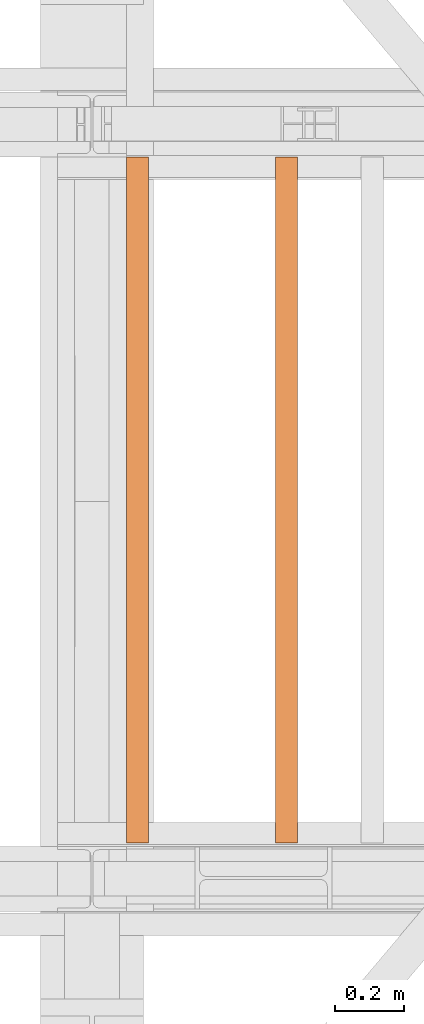
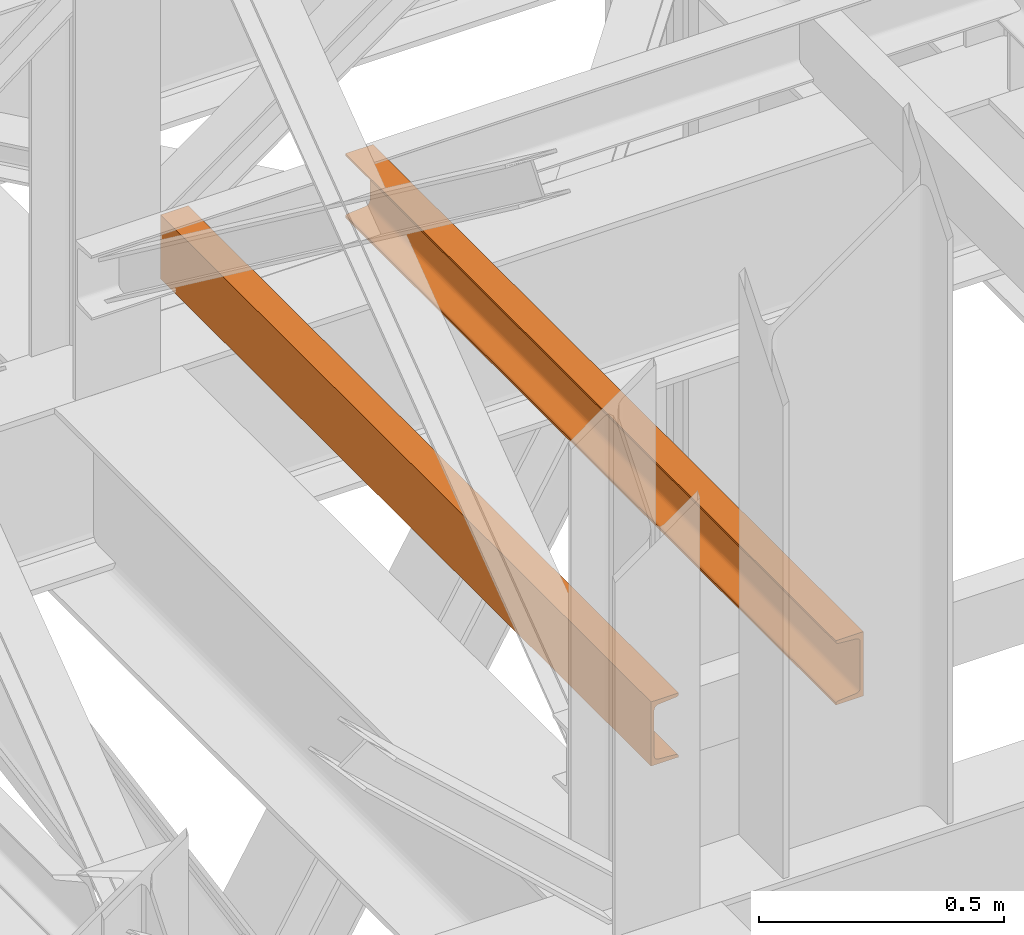
# One storey, part 170 of 208: 2 proxies.
"""IFC2X3 building model written with IfcOpenShell, lengths in millimetres."""

from ifc_helpers import new_model, entity, si_unit, converted_unit, frame, origin, origin_with_axes, place, context, subcontext, project, spatial, faceted_brep, element, save


model = new_model("IFC2X3")

# Units and contexts
model_context = context("Model", 3, precision=1e-05, world=origin())
plan_context = context("Plan", 3, precision=1e-05, world=origin())
body_context = subcontext(model_context, "Body", "Model", "MODEL_VIEW")
ifc_project = project(units=[si_unit("LENGTHUNIT", "METRE", prefix="MILLI"), converted_unit("PLANEANGLEUNIT", "DEGREE", entity("IfcPlaneAngleMeasure", 0.0174532925199433), si_unit("PLANEANGLEUNIT", "RADIAN"), dimensions=[0, 0, 0, 0, 0, 0, 0]), si_unit("AREAUNIT", "SQUARE_METRE"), si_unit("VOLUMEUNIT", "CUBIC_METRE")], contexts=[model_context, plan_context])

# Building, storey
building_placement = place(None, origin())
building = spatial("IfcBuilding", under=ifc_project, at=building_placement, CompositionType="COMPLEX")
storey_placement = place(building_placement, origin_with_axes())
storey = spatial("IfcBuildingStorey", under=building, at=storey_placement, Name="Geschoss", CompositionType="ELEMENT")

# Proxies
proxy_1_placement = place(storey_placement, frame((6693.254970018781, -15857.57439274273, 5518.360005364418), z_axis=(0.0, 0.0, 1.0), x_axis=(1.0, 0.0, 0.0)))
element("IfcBuildingElementProxy", 1, at=proxy_1_placement, inside=storey, context=body_context, shape_type="Brep", body=[
    faceted_brep([(0.01000000000203727, 2000.009997019768, 160.0100000000002), (65.01000000000204, 2000.009997019768, 160.0100000000002), (65.01000000000022, 0.01000000000021828, 160.0100000000002), (0.01000000000021828, 0.01000000000021828, 160.0100000000002), (65.01000000000204, 2000.009997019768, 160.0100000000002), (65.01000000000204, 2000.009997019768, 156.8875719297539), (65.01000000000022, 0.01000000000021828, 156.8875719297539), (65.01000000000022, 0.01000000000021828, 160.0100000000002), (65.01000000000204, 2000.009997019768, 156.8875719297539), (64.76726342282927, 2000.009997019768, 155.2717110918293), (64.76726342282745, 0.01000000000021828, 155.2717110918293), (65.01000000000022, 0.01000000000021828, 156.8875719297539), (64.76726342282927, 2000.009997019768, 155.2717110918293), (64.06053228585733, 2000.009997019768, 153.7984655565542), (64.06053228585915, 0.01000000000021828, 153.7984655565542), (64.76726342282745, 0.01000000000021828, 155.2717110918293), (64.06053228585733, 2000.009997019768, 153.7984655565542), (62.95215163847024, 2000.009997019768, 152.5978732961266), (62.95215163846842, 0.01000000000021828, 152.5978732961266), (64.06053228585915, 0.01000000000021828, 153.7984655565542), (62.95215163847024, 2000.009997019768, 152.5978732961266), (61.53995641148504, 2000.009997019768, 151.7759086082897), (61.53995641148322, 0.01000000000021828, 151.7759086082897), (62.95215163846842, 0.01000000000021828, 152.5978732961266), (61.53995641148504, 2000.009997019768, 151.7759086082897), (59.9485987225562, 2000.009997019768, 151.4050878978051), (59.94859872255438, 0.01000000000021828, 151.4050878978051), (61.53995641148322, 0.01000000000021828, 151.7759086082897), (59.9485987225562, 2000.009997019768, 151.4050878978051), (17.1726751660317, 2000.009997019768, 147.9830140132835), (17.17267516602988, 0.01000000000021828, 147.9830140132835), (59.94859872255438, 0.01000000000021828, 151.4050878978051), (17.1726751660317, 2000.009997019768, 147.9830140132835), (14.20840820801095, 2000.009997019768, 147.318026761528), (14.20840820800913, 0.01000000000021828, 147.318026761528), (17.17267516602988, 0.01000000000021828, 147.9830140132835), (14.20840820801095, 2000.009997019768, 147.318026761528), (11.43861959928836, 2000.009997019768, 145.7058782528511), (11.43861959929018, 0.01000000000021828, 145.7058782528511), (14.20840820800913, 0.01000000000021828, 147.318026761528), (11.43861959928836, 2000.009997019768, 145.7058782528511), (9.3226201815487, 2000.009997019768, 143.4138384829421), (9.322620181546881, 0.01000000000021828, 143.4138384829421), (11.43861959929018, 0.01000000000021828, 145.7058782528511), (9.3226201815487, 2000.009997019768, 143.4138384829421), (7.973406192788389, 2000.009997019768, 140.6012788246917), (7.97340619278657, 0.01000000000021828, 140.6012788246917), (9.322620181546881, 0.01000000000021828, 143.4138384829421), (7.973406192788389, 2000.009997019768, 140.6012788246917), (7.510000000002037, 2000.009997019768, 137.5164535886543), (7.510000000000218, 0.01000000000021828, 137.5164535886543), (7.97340619278657, 0.01000000000021828, 140.6012788246917), (7.510000000002037, 2000.009997019768, 137.5164535886543), (7.510000000002037, 2000.009997019768, 22.503546411348), (7.510000000000218, 0.01000000000021828, 22.503546411348), (7.510000000000218, 0.01000000000021828, 137.5164535886543), (7.510000000002037, 2000.009997019768, 22.503546411348), (7.973406192788389, 2000.009997019768, 19.41872117530875), (7.97340619278657, 0.01000000000021828, 19.41872117530875), (7.510000000000218, 0.01000000000021828, 22.503546411348), (7.973406192788389, 2000.009997019768, 19.41872117530875), (9.3226201815487, 2000.009997019768, 16.60616151705835), (9.322620181546881, 0.01000000000021828, 16.60616151705835), (7.97340619278657, 0.01000000000021828, 19.41872117530875), (9.3226201815487, 2000.009997019768, 16.60616151705835), (11.43861959928836, 2000.009997019768, 14.31412174714933), (11.43861959929018, 0.01000000000021828, 14.31412174714933), (9.322620181546881, 0.01000000000021828, 16.60616151705835), (11.43861959928836, 2000.009997019768, 14.31412174714933), (14.13462866898408, 2000.009997019768, 12.74491643400688), (14.1346286689859, 0.01000000000021828, 12.74491643400688), (11.43861959929018, 0.01000000000021828, 14.31412174714933), (14.13462866898408, 2000.009997019768, 12.74491643400688), (17.1726751660317, 2000.009997019768, 12.03698598671872), (17.17267516602988, 0.01000000000021828, 12.03698598671872), (14.1346286689859, 0.01000000000021828, 12.74491643400688), (17.1726751660317, 2000.009997019768, 12.03698598671872), (59.9485987225562, 2000.009997019768, 8.614912102195376), (59.94859872255438, 0.01000000000021828, 8.614912102195376), (17.17267516602988, 0.01000000000021828, 12.03698598671872), (59.9485987225562, 2000.009997019768, 8.614912102195376), (61.53995641148504, 2000.009997019768, 8.244091391710754), (61.53995641148322, 0.01000000000021828, 8.244091391710754), (59.94859872255438, 0.01000000000021828, 8.614912102195376), (61.53995641148504, 2000.009997019768, 8.244091391710754), (62.95215163847024, 2000.009997019768, 7.422126703873801), (62.95215163846842, 0.01000000000021828, 7.422126703873801), (61.53995641148322, 0.01000000000021828, 8.244091391710754), (62.95215163847024, 2000.009997019768, 7.422126703873801), (64.06053228585733, 2000.009997019768, 6.221534443446217), (64.06053228585915, 0.01000000000021828, 6.221534443446217), (62.95215163846842, 0.01000000000021828, 7.422126703873801), (64.06053228585733, 2000.009997019768, 6.221534443446217), (64.76726342282927, 2000.009997019768, 4.748288908172981), (64.76726342282745, 0.01000000000021828, 4.748288908172981), (64.06053228585915, 0.01000000000021828, 6.221534443446217), (64.76726342282927, 2000.009997019768, 4.748288908172981), (65.01000000000204, 2000.009997019768, 0.01000000000021828), (65.01000000000022, 0.01000000000021828, 0.01000000000021828), (64.76726342282745, 0.01000000000021828, 4.748288908172981), (65.01000000000204, 2000.009997019768, 0.01000000000021828), (0.01000000000203727, 2000.009997019768, 0.01000000000021828), (0.01000000000021828, 0.01000000000021828, 0.01000000000021828), (65.01000000000022, 0.01000000000021828, 0.01000000000021828), (0.01000000000203727, 2000.009997019768, 0.01000000000021828), (0.01000000000203727, 2000.009997019768, 160.0100000000002), (0.01000000000021828, 0.01000000000021828, 160.0100000000002), (0.01000000000021828, 0.01000000000021828, 0.01000000000021828), (0.01000000000203727, 2000.009997019768, 160.0100000000002), (0.01000000000203727, 2000.009997019768, 0.01000000000021828), (65.01000000000204, 2000.009997019768, 0.01000000000021828), (64.76726342282927, 2000.009997019768, 4.748288908172981), (64.06053228585733, 2000.009997019768, 6.221534443446217), (62.95215163847024, 2000.009997019768, 7.422126703873801), (61.53995641148504, 2000.009997019768, 8.244091391710754), (59.9485987225562, 2000.009997019768, 8.614912102195376), (17.1726751660317, 2000.009997019768, 12.03698598671872), (14.13462866898408, 2000.009997019768, 12.74491643400688), (11.43861959928836, 2000.009997019768, 14.31412174714933), (9.3226201815487, 2000.009997019768, 16.60616151705835), (7.973406192788389, 2000.009997019768, 19.41872117530875), (7.510000000002037, 2000.009997019768, 22.503546411348), (7.510000000002037, 2000.009997019768, 137.5164535886543), (7.973406192788389, 2000.009997019768, 140.6012788246917), (9.3226201815487, 2000.009997019768, 143.4138384829421), (11.43861959928836, 2000.009997019768, 145.7058782528511), (14.20840820801095, 2000.009997019768, 147.318026761528), (17.1726751660317, 2000.009997019768, 147.9830140132835), (59.9485987225562, 2000.009997019768, 151.4050878978051), (61.53995641148504, 2000.009997019768, 151.7759086082897), (62.95215163847024, 2000.009997019768, 152.5978732961266), (64.06053228585733, 2000.009997019768, 153.7984655565542), (64.76726342282927, 2000.009997019768, 155.2717110918293), (65.01000000000204, 2000.009997019768, 156.8875719297539), (65.01000000000204, 2000.009997019768, 160.0100000000002), (0.01000000000021828, 0.01000000000021828, 160.0100000000002), (65.01000000000022, 0.01000000000021828, 160.0100000000002), (65.01000000000022, 0.01000000000021828, 156.8875719297539), (64.76726342282745, 0.01000000000021828, 155.2717110918293), (64.06053228585915, 0.01000000000021828, 153.7984655565542), (62.95215163846842, 0.01000000000021828, 152.5978732961266), (61.53995641148322, 0.01000000000021828, 151.7759086082897), (59.94859872255438, 0.01000000000021828, 151.4050878978051), (17.17267516602988, 0.01000000000021828, 147.9830140132835), (14.20840820800913, 0.01000000000021828, 147.318026761528), (11.43861959929018, 0.01000000000021828, 145.7058782528511), (9.322620181546881, 0.01000000000021828, 143.4138384829421), (7.97340619278657, 0.01000000000021828, 140.6012788246917), (7.510000000000218, 0.01000000000021828, 137.5164535886543), (7.510000000000218, 0.01000000000021828, 22.503546411348), (7.97340619278657, 0.01000000000021828, 19.41872117530875), (9.322620181546881, 0.01000000000021828, 16.60616151705835), (11.43861959929018, 0.01000000000021828, 14.31412174714933), (14.1346286689859, 0.01000000000021828, 12.74491643400688), (17.17267516602988, 0.01000000000021828, 12.03698598671872), (59.94859872255438, 0.01000000000021828, 8.614912102195376), (61.53995641148322, 0.01000000000021828, 8.244091391710754), (62.95215163846842, 0.01000000000021828, 7.422126703873801), (64.06053228585915, 0.01000000000021828, 6.221534443446217), (64.76726342282745, 0.01000000000021828, 4.748288908172981), (65.01000000000022, 0.01000000000021828, 0.01000000000021828), (0.01000000000021828, 0.01000000000021828, 0.01000000000021828)], [[[0, 1, 2, 3]], [[4, 5, 6, 7]], [[8, 9, 10, 11]], [[12, 13, 14, 15]], [[16, 17, 18, 19]], [[20, 21, 22, 23]], [[24, 25, 26, 27]], [[28, 29, 30, 31]], [[32, 33, 34, 35]], [[36, 37, 38, 39]], [[40, 41, 42, 43]], [[44, 45, 46, 47]], [[48, 49, 50, 51]], [[52, 53, 54, 55]], [[56, 57, 58, 59]], [[60, 61, 62, 63]], [[64, 65, 66, 67]], [[68, 69, 70, 71]], [[72, 73, 74, 75]], [[76, 77, 78, 79]], [[80, 81, 82, 83]], [[84, 85, 86, 87]], [[88, 89, 90, 91]], [[92, 93, 94, 95]], [[96, 97, 98, 99]], [[100, 101, 102, 103]], [[104, 105, 106, 107]], [[108, 109, 110, 111, 112, 113, 114, 115, 116, 117, 118, 119, 120, 121, 122, 123, 124, 125, 126, 127, 128, 129, 130, 131, 132, 133, 134]], [[135, 136, 137, 138, 139, 140, 141, 142, 143, 144, 145, 146, 147, 148, 149, 150, 151, 152, 153, 154, 155, 156, 157, 158, 159, 160, 161]]], orient=[[False], [False], [False], [False], [False], [False], [False], [False], [False], [False], [False], [False], [False], [False], [False], [False], [False], [False], [False], [False], [False], [False], [False], [False], [False], [False], [False], [False], [False]]),
])
proxy_2_placement = place(storey_placement, frame((7128.254968528667, -15857.57439274273, 5518.360005364419), z_axis=(0.0, 0.0, 1.0), x_axis=(1.0, 0.0, 0.0)))
element("IfcBuildingElementProxy", 2, at=proxy_2_placement, inside=storey, context=body_context, shape_type="Brep", body=[
    faceted_brep([(65.01000000000022, 2000.009997019768, 160.0100000000002), (65.01000000000204, 0.01000000000021828, 160.0100000000002), (0.01000000000203727, 0.01000000000021828, 160.0100000000002), (0.01000000000021828, 2000.009997019768, 160.0100000000002), (0.01000000000021828, 2000.009997019768, 160.0100000000002), (0.01000000000203727, 0.01000000000021828, 160.0100000000002), (0.01000000000203727, 0.01000000000021828, 156.8875719297539), (0.01000000000021828, 2000.009997019768, 156.8875719297539), (0.01000000000021828, 2000.009997019768, 156.8875719297539), (0.01000000000203727, 0.01000000000021828, 156.8875719297539), (0.2527365771748009, 0.01000000000021828, 155.2717110918293), (0.2527365771729819, 2000.009997019768, 155.2717110918293), (0.2527365771729819, 2000.009997019768, 155.2717110918293), (0.2527365771748009, 0.01000000000021828, 155.2717110918293), (0.9594677141431021, 0.01000000000021828, 153.7984655565542), (0.959467714144921, 2000.009997019768, 153.7984655565542), (0.959467714144921, 2000.009997019768, 153.7984655565542), (0.9594677141431021, 0.01000000000021828, 153.7984655565542), (2.067848361533834, 0.01000000000021828, 152.5978732961266), (2.067848361532015, 2000.009997019768, 152.5978732961266), (2.067848361532015, 2000.009997019768, 152.5978732961266), (2.067848361533834, 0.01000000000021828, 152.5978732961266), (3.480043588519038, 0.01000000000021828, 151.7759086082897), (3.480043588517219, 2000.009997019768, 151.7759086082897), (3.480043588517219, 2000.009997019768, 151.7759086082897), (3.480043588519038, 0.01000000000021828, 151.7759086082897), (5.071401277447876, 0.01000000000021828, 151.4050878978051), (5.071401277446057, 2000.009997019768, 151.4050878978051), (5.071401277446057, 2000.009997019768, 151.4050878978051), (5.071401277447876, 0.01000000000021828, 151.4050878978051), (47.84732483397238, 0.01000000000021828, 147.9830140132835), (47.84732483397056, 2000.009997019768, 147.9830140132835), (47.84732483397056, 2000.009997019768, 147.9830140132835), (47.84732483397238, 0.01000000000021828, 147.9830140132835), (50.81159179199312, 0.01000000000021828, 147.318026761528), (50.8115917919913, 2000.009997019768, 147.318026761528), (50.8115917919913, 2000.009997019768, 147.318026761528), (50.81159179199312, 0.01000000000021828, 147.318026761528), (53.58138040071208, 0.01000000000021828, 145.7058782528511), (53.5813804007139, 2000.009997019768, 145.7058782528511), (53.5813804007139, 2000.009997019768, 145.7058782528511), (53.58138040071208, 0.01000000000021828, 145.7058782528511), (55.69737981845537, 0.01000000000021828, 143.4138384829421), (55.69737981845356, 2000.009997019768, 143.4138384829421), (55.69737981845356, 2000.009997019768, 143.4138384829421), (55.69737981845537, 0.01000000000021828, 143.4138384829421), (57.04659380721569, 0.01000000000021828, 140.6012788246917), (57.04659380721387, 2000.009997019768, 140.6012788246917), (57.04659380721387, 2000.009997019768, 140.6012788246917), (57.04659380721569, 0.01000000000021828, 140.6012788246917), (57.51000000000204, 0.01000000000021828, 137.5164535886543), (57.51000000000022, 2000.009997019768, 137.5164535886543), (57.51000000000022, 2000.009997019768, 137.5164535886543), (57.51000000000204, 0.01000000000021828, 137.5164535886543), (57.51000000000204, 0.01000000000021828, 22.503546411348), (57.51000000000022, 2000.009997019768, 22.503546411348), (57.51000000000022, 2000.009997019768, 22.503546411348), (57.51000000000204, 0.01000000000021828, 22.503546411348), (57.04659380721569, 0.01000000000021828, 19.41872117530875), (57.04659380721387, 2000.009997019768, 19.41872117530875), (57.04659380721387, 2000.009997019768, 19.41872117530875), (57.04659380721569, 0.01000000000021828, 19.41872117530875), (55.69737981845537, 0.01000000000021828, 16.60616151705835), (55.69737981845356, 2000.009997019768, 16.60616151705835), (55.69737981845356, 2000.009997019768, 16.60616151705835), (55.69737981845537, 0.01000000000021828, 16.60616151705835), (53.58138040071208, 0.01000000000021828, 14.31412174714933), (53.5813804007139, 2000.009997019768, 14.31412174714933), (53.5813804007139, 2000.009997019768, 14.31412174714933), (53.58138040071208, 0.01000000000021828, 14.31412174714933), (50.88537133101636, 0.01000000000021828, 12.74491643400688), (50.88537133101818, 2000.009997019768, 12.74491643400688), (50.88537133101818, 2000.009997019768, 12.74491643400688), (50.88537133101636, 0.01000000000021828, 12.74491643400688), (47.84732483397238, 0.01000000000021828, 12.03698598671872), (47.84732483397056, 2000.009997019768, 12.03698598671872), (47.84732483397056, 2000.009997019768, 12.03698598671872), (47.84732483397238, 0.01000000000021828, 12.03698598671872), (5.071401277447876, 0.01000000000021828, 8.614912102195376), (5.071401277446057, 2000.009997019768, 8.614912102195376), (5.071401277446057, 2000.009997019768, 8.614912102195376), (5.071401277447876, 0.01000000000021828, 8.614912102195376), (3.480043588519038, 0.01000000000021828, 8.244091391710754), (3.480043588517219, 2000.009997019768, 8.244091391710754), (3.480043588517219, 2000.009997019768, 8.244091391710754), (3.480043588519038, 0.01000000000021828, 8.244091391710754), (2.067848361533834, 0.01000000000021828, 7.422126703873801), (2.067848361532015, 2000.009997019768, 7.422126703873801), (2.067848361532015, 2000.009997019768, 7.422126703873801), (2.067848361533834, 0.01000000000021828, 7.422126703873801), (0.9594677141431021, 0.01000000000021828, 6.221534443446217), (0.959467714144921, 2000.009997019768, 6.221534443446217), (0.959467714144921, 2000.009997019768, 6.221534443446217), (0.9594677141431021, 0.01000000000021828, 6.221534443446217), (0.2527365771748009, 0.01000000000021828, 4.748288908172981), (0.2527365771729819, 2000.009997019768, 4.748288908172981), (0.2527365771729819, 2000.009997019768, 4.748288908172981), (0.2527365771748009, 0.01000000000021828, 4.748288908172981), (0.01000000000203727, 0.01000000000021828, 0.01000000000021828), (0.01000000000021828, 2000.009997019768, 0.01000000000021828), (0.01000000000021828, 2000.009997019768, 0.01000000000021828), (0.01000000000203727, 0.01000000000021828, 0.01000000000021828), (65.01000000000204, 0.01000000000021828, 0.01000000000021828), (65.01000000000022, 2000.009997019768, 0.01000000000021828), (65.01000000000022, 2000.009997019768, 0.01000000000021828), (65.01000000000204, 0.01000000000021828, 0.01000000000021828), (65.01000000000204, 0.01000000000021828, 160.0100000000002), (65.01000000000022, 2000.009997019768, 160.0100000000002), (65.01000000000022, 2000.009997019768, 160.0100000000002), (0.01000000000021828, 2000.009997019768, 160.0100000000002), (0.01000000000021828, 2000.009997019768, 156.8875719297539), (0.2527365771729819, 2000.009997019768, 155.2717110918293), (0.959467714144921, 2000.009997019768, 153.7984655565542), (2.067848361532015, 2000.009997019768, 152.5978732961266), (3.480043588517219, 2000.009997019768, 151.7759086082897), (5.071401277446057, 2000.009997019768, 151.4050878978051), (47.84732483397056, 2000.009997019768, 147.9830140132835), (50.8115917919913, 2000.009997019768, 147.318026761528), (53.5813804007139, 2000.009997019768, 145.7058782528511), (55.69737981845356, 2000.009997019768, 143.4138384829421), (57.04659380721387, 2000.009997019768, 140.6012788246917), (57.51000000000022, 2000.009997019768, 137.5164535886543), (57.51000000000022, 2000.009997019768, 22.503546411348), (57.04659380721387, 2000.009997019768, 19.41872117530875), (55.69737981845356, 2000.009997019768, 16.60616151705835), (53.5813804007139, 2000.009997019768, 14.31412174714933), (50.88537133101818, 2000.009997019768, 12.74491643400688), (47.84732483397056, 2000.009997019768, 12.03698598671872), (5.071401277446057, 2000.009997019768, 8.614912102195376), (3.480043588517219, 2000.009997019768, 8.244091391710754), (2.067848361532015, 2000.009997019768, 7.422126703873801), (0.959467714144921, 2000.009997019768, 6.221534443446217), (0.2527365771729819, 2000.009997019768, 4.748288908172981), (0.01000000000021828, 2000.009997019768, 0.01000000000021828), (65.01000000000022, 2000.009997019768, 0.01000000000021828), (65.01000000000204, 0.01000000000021828, 160.0100000000002), (65.01000000000204, 0.01000000000021828, 0.01000000000021828), (0.01000000000203727, 0.01000000000021828, 0.01000000000021828), (0.2527365771748009, 0.01000000000021828, 4.748288908172981), (0.9594677141431021, 0.01000000000021828, 6.221534443446217), (2.067848361533834, 0.01000000000021828, 7.422126703873801), (3.480043588519038, 0.01000000000021828, 8.244091391710754), (5.071401277447876, 0.01000000000021828, 8.614912102195376), (47.84732483397238, 0.01000000000021828, 12.03698598671872), (50.88537133101636, 0.01000000000021828, 12.74491643400688), (53.58138040071208, 0.01000000000021828, 14.31412174714933), (55.69737981845537, 0.01000000000021828, 16.60616151705835), (57.04659380721569, 0.01000000000021828, 19.41872117530875), (57.51000000000204, 0.01000000000021828, 22.503546411348), (57.51000000000204, 0.01000000000021828, 137.5164535886543), (57.04659380721569, 0.01000000000021828, 140.6012788246917), (55.69737981845537, 0.01000000000021828, 143.4138384829421), (53.58138040071208, 0.01000000000021828, 145.7058782528511), (50.81159179199312, 0.01000000000021828, 147.318026761528), (47.84732483397238, 0.01000000000021828, 147.9830140132835), (5.071401277447876, 0.01000000000021828, 151.4050878978051), (3.480043588519038, 0.01000000000021828, 151.7759086082897), (2.067848361533834, 0.01000000000021828, 152.5978732961266), (0.9594677141431021, 0.01000000000021828, 153.7984655565542), (0.2527365771748009, 0.01000000000021828, 155.2717110918293), (0.01000000000203727, 0.01000000000021828, 156.8875719297539), (0.01000000000203727, 0.01000000000021828, 160.0100000000002)], [[[0, 1, 2, 3]], [[4, 5, 6, 7]], [[8, 9, 10, 11]], [[12, 13, 14, 15]], [[16, 17, 18, 19]], [[20, 21, 22, 23]], [[24, 25, 26, 27]], [[28, 29, 30, 31]], [[32, 33, 34, 35]], [[36, 37, 38, 39]], [[40, 41, 42, 43]], [[44, 45, 46, 47]], [[48, 49, 50, 51]], [[52, 53, 54, 55]], [[56, 57, 58, 59]], [[60, 61, 62, 63]], [[64, 65, 66, 67]], [[68, 69, 70, 71]], [[72, 73, 74, 75]], [[76, 77, 78, 79]], [[80, 81, 82, 83]], [[84, 85, 86, 87]], [[88, 89, 90, 91]], [[92, 93, 94, 95]], [[96, 97, 98, 99]], [[100, 101, 102, 103]], [[104, 105, 106, 107]], [[108, 109, 110, 111, 112, 113, 114, 115, 116, 117, 118, 119, 120, 121, 122, 123, 124, 125, 126, 127, 128, 129, 130, 131, 132, 133, 134]], [[135, 136, 137, 138, 139, 140, 141, 142, 143, 144, 145, 146, 147, 148, 149, 150, 151, 152, 153, 154, 155, 156, 157, 158, 159, 160, 161]]], orient=[[False], [False], [False], [False], [False], [False], [False], [False], [False], [False], [False], [False], [False], [False], [False], [False], [False], [False], [False], [False], [False], [False], [False], [False], [False], [False], [False], [False], [False]]),
])

save(model, "model.ifc")
